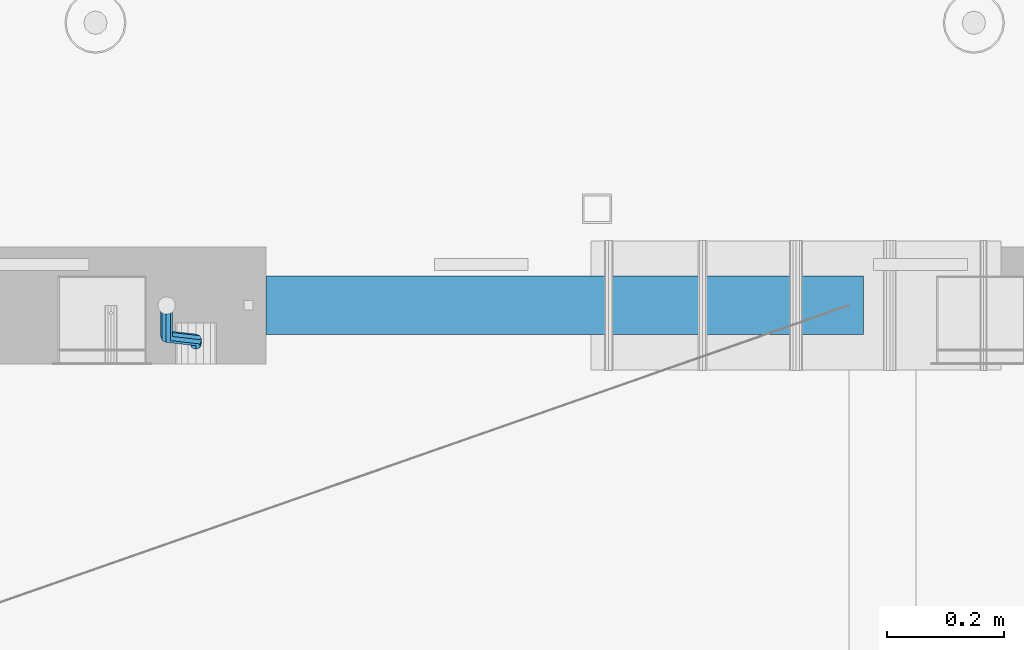
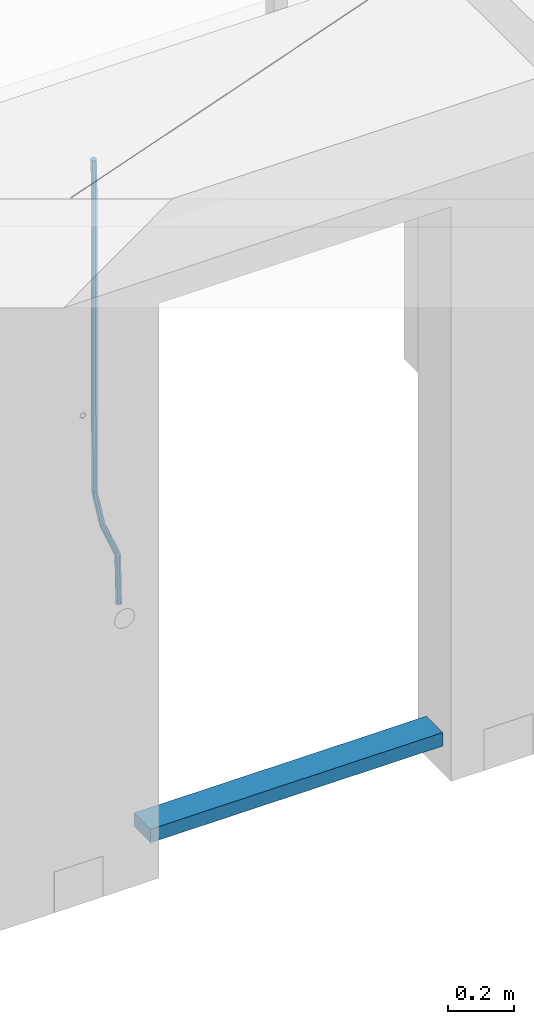
# One storey, part 95 of 309: 2 beams, 1 element without a shape of its own.
"""IFC2X3 building model written with IfcOpenShell, lengths in millimetres."""

from ifc_helpers import new_model, si_unit, frame, origin_with_axes, place, context, subcontext, project, spatial, faceted_brep, material, type_object, element, aggregate, save


model = new_model("IFC2X3")

# Units and contexts
model_context = context("Model", 3, precision=1e-05, world=origin_with_axes())
body_context = subcontext(model_context, "Body", "Model", "MODEL_VIEW")
ifc_project = project(units=[si_unit("LENGTHUNIT", "METRE", prefix="MILLI"), si_unit("AREAUNIT", "SQUARE_METRE"), si_unit("VOLUMEUNIT", "CUBIC_METRE"), si_unit("MASSUNIT", "GRAM", prefix="KILO"), si_unit("TIMEUNIT", "SECOND"), si_unit("PLANEANGLEUNIT", "RADIAN"), si_unit("SOLIDANGLEUNIT", "STERADIAN"), si_unit("THERMODYNAMICTEMPERATUREUNIT", "DEGREE_CELSIUS"), si_unit("LUMINOUSINTENSITYUNIT", "LUMEN")], contexts=[model_context])

# Site, building, storey
site_placement = place(None, origin_with_axes())
site = spatial("IfcSite", under=ifc_project, at=site_placement, CompositionType="ELEMENT")
building_placement = place(site_placement, origin_with_axes())
building = spatial("IfcBuilding", under=site, at=building_placement, CompositionType="ELEMENT")
storey_placement = place(building_placement, origin_with_axes())
storey = spatial("IfcBuildingStorey", under=building, at=storey_placement, Name="7", CompositionType="ELEMENT", Elevation=0.0)

# Assembly, beams
assembly_placement = place(storey_placement, origin_with_axes())
assembly = element("IfcElementAssembly", 1, at=assembly_placement, inside=storey, AssemblyPlace="NOTDEFINED", PredefinedType="REINFORCEMENT_UNIT")
ifc_material_1 = material()
beam_type_1 = type_object("IfcBeamType", Name="D20", PredefinedType="NOTDEFINED")
beam_1_placement = place(assembly_placement, frame((24379.9991455117, 15114.989587991, 100790.007632439), z_axis=(-0.000205762999925498, 0.999642804629538, -0.0267249099901004), x_axis=(4.30000201928125e-08, 0.0267249099948059, 0.999642825806181)))
beam_1 = element("IfcBeam", 2, at=beam_1_placement, type_object=beam_type_1, material=ifc_material_1, Name="JM20", ObjectType="D20", context=body_context, shape_type="Brep", body=[
    faceted_brep([(0.0, -10.0, 0.0), (-4.19531716033816e-08, -7.07106781186667, -7.07106781187031), (60.4266690400545, -7.0710677960451, -7.07106780570757), (60.4266690441291, -9.99999998418934, 6.15546014159918e-09), (0.0, 0.0, -10.0), (60.426669036824, 1.58106558956206e-08, -9.99999999384454), (4.196772351861e-08, 7.07106781186303, -7.07106781186667), (60.4266690363438, 7.07106782768096, -7.07106780570757), (0.0, 10.0, 0.0), (60.4266690388904, 10.0000000158179, 6.15182216279209e-09), (4.196772351861e-08, 7.07106781185939, 7.07106781185939), (60.4266690429649, 7.07106782768096, 7.07106781802577), (0.0, 0.0, 10.0), (60.4266690461809, 1.58179318532348e-08, 10.0000000061555), (-4.19531716033816e-08, -7.07106781187031, 7.07106781185939), (60.4266690466611, -7.07106779605238, 7.07106781802213), (61.0378400410118, -7.07106779588503, -7.07106780564936), (60.991799419251, -9.99999998403655, 6.21366780251265e-09), (61.0569027789461, 1.5985278878361e-08, -9.99999999378269), (61.0378209396877, 7.07106782784831, -7.07106780564936), (60.9917724058905, 10.0000000159635, 6.21366780251265e-09), (60.9457317841297, 7.07106782781193, 7.0710678180767), (60.9266690461809, 1.59488990902901e-08, 10.0000000062028), (60.9457508854539, -7.07106779591413, 7.0710678180767), (61.6489592143771, -7.07106614513759, -7.06310863441468), (61.5568818710308, -9.9999984576425, 0.00735959856683621), (61.6870830769039, 1.71821739058942e-06, -9.99179257185824), (61.6489210170112, 7.07106947854481, -7.06310888312146), (61.556827851804, 10.0000015422847, 0.00735924683976918), (61.4647505084577, 7.07106922979438, 7.07782747982128), (61.4266266459163, 1.36643211590126e-06, 10.0065114172685), (61.464788705809, -7.07106639389531, 7.07782772852806), (174.621213165461, -7.07076098345351, -5.59176629582907), (174.529135822144, -9.99969329595478, 1.4787019371488), (174.659337027944, 0.000306879905110691, -8.52045023327446), (174.621174967935, 7.07137464022526, -5.59176654453404), (174.529081802684, 10.0003067039688, 1.47870158543083), (174.437004459352, 7.07137439147118, 8.5491698184087), (174.398880596913, 0.000306528108922066, 11.4778537558541), (174.437042656878, -7.07076123221123, 8.54917006711185), (175.716094779258, -7.07075802595864, -5.57750663810293), (175.029093421879, -9.99969194546793, 1.48521334821271), (177.145578432857, 0.000313595744955819, -8.48806960781258), (178.480172245545, 7.07138506415868, -5.54150724740612), (178.938089262141, 10.0003186135946, 1.53612417477052), (178.251087904748, 7.07138469408164, 8.59884416108434), (176.821604251149, 0.000313072378048673, 11.5094071307958), (175.487010438475, -7.07075839603567, 8.56284477038935), (176.73028205616, -7.48306481911277, -5.5575978012148), (175.49220343327, -10.1879642774365, 1.49430435328395), (179.448580299344, -0.935946733912715, -8.44286090764945), (182.054755918522, 5.61817699831226, -5.47133696928722), (183.022146581905, 8.33998958468874, 1.61629559169705), (181.784067959001, 5.63509012636496, 8.6681977461958), (179.065769715831, -0.912027958831459, 11.5534608526305), (176.459594096654, -7.4661516910528, 8.58193691426459), (294.295456565174, -55.2779062578775, -3.24975393820569), (293.057377942285, -57.9828057162013, 3.80214821629306), (297.013754808359, -48.7307881726811, -6.13501704463852), (299.619930427536, -42.1766644404597, -3.16349310627629), (300.587321090919, -39.454851854076, 3.92413945470616), (299.34924246803, -42.1597513124034, 10.9760416092031), (296.630944224846, -48.7068693975998, 13.8613047156396), (294.024768605668, -55.2609931298248, 10.8897807772755), (300.131186042752, -57.6503585272258, -3.13519660847487), (297.927214299008, -59.9625846556301, 3.89774473963917), (302.241773597852, -50.8561822796182, -6.0323892798333), (303.022623399127, -43.5599922135116, -3.09669710035814), (302.016324223136, -40.0357975159677, 3.95219126616212), (299.812352479406, -42.3480236443684, 10.9851326142743), (297.701764924292, -49.1421998919686, 13.8823252856328), (296.920915123032, -56.4383899580826, 10.9466331061594), (305.816309115588, -57.6497962814865, -0.41917616768842), (302.671371672826, -59.9621154692577, 6.16422661461002), (307.334869561208, -50.8556785840192, -3.59920488503303), (306.337500895927, -43.5596643796707, -1.51304184353285), (303.408448157163, -40.0356598380822, 4.61726694041863), (300.263510714387, -42.3479790258461, 11.2006697227207), (298.744950268767, -49.1420967233171, 14.3806984400617), (299.742318934063, -56.4381109276655, 12.2945353985633), (395.630203780689, -57.6409138916788, 42.488667805259), (392.485266337913, -59.9532330794427, 49.0720705875574), (397.148764226309, -50.8467961942151, 39.3086390879143), (396.151395561013, -43.5507819898594, 41.3948021294145), (393.22234282225, -40.0267774482672, 47.5251109133696), (390.077405379474, -42.3390966360348, 54.1085136956717), (388.558844933854, -49.1332143335057, 57.2885424130127), (389.556213599149, -56.4292285378579, 55.2023793715125), (396.844209099741, -57.640793829316, 43.0686487871244), (395.280625423067, -59.9529566247911, 50.4075302279853), (397.599922461304, -50.8467515756856, 39.5241761963625), (397.10507886979, -43.5506876727486, 41.8504164279075), (395.649550989881, -40.0265374029004, 48.6846895034632), (394.085967313207, -42.3387001983865, 56.0235709443259), (393.330253951674, -49.1327424520096, 59.5680435350878), (393.825097543173, -56.4288063549466, 57.241803303541), (398.189189358192, -57.6411602552034, 43.0337942646147), (398.377566371972, -59.9538003541529, 50.3272744790011), (398.099754636642, -50.8468877497689, 39.5112232837091), (398.161651854258, -43.550975525075, 41.8230358424771), (398.338622460418, -40.027270012466, 48.6150034976581), (398.526999474212, -42.3399101114192, 55.9084837120445), (398.616434195777, -49.13418261685, 59.4310546929501), (398.554536978161, -56.4300948415512, 57.1192421341821), (1517.19478070838, -57.9460216934422, 14.0352975759452), (1517.38315772217, -60.2586617923953, 21.3287777903333), (1517.10534598683, -51.1517491880113, 10.5127265950414), (1517.16724320444, -43.8558369633138, 12.8245391538094), (1517.34421381062, -40.3321314507048, 19.6165068089904), (1517.53259082441, -42.6447715496579, 26.9099870233767), (1517.62202554596, -49.4390440550887, 30.4325580042841), (1517.56012832835, -56.7349562797899, 28.1207454455143), (1518.02724982343, -57.946248491, 14.0137245355054), (1518.07759034891, -60.258850983344, 21.3107818997123), (1517.99524544395, -51.1519916318648, 10.4896652746502), (1518.00032494192, -43.8560639277712, 12.8029502375484), (1518.03951281632, -40.3323208776928, 19.5984884665704), (1518.08985334181, -42.6449233700369, 26.8955458307773), (1518.12185772131, -49.4391802291757, 30.4196050916289), (1518.11677822332, -56.735107933262, 28.1063201287325), (1518.85992470267, -57.9437654472204, 14.0245252313944), (1518.77219462092, -60.2567796673247, 21.3197916701429), (1518.8853648605, -51.149337287974, 10.5012110884654), (1518.83361259502, -43.8535790567003, 12.8137588817826), (1518.73498368141, -40.3302469774862, 19.6075094776534), (1518.64725359967, -42.6432611975906, 26.9027759164019), (1518.62181344185, -49.4376893568369, 30.4260900593326), (1518.67356570732, -56.7334475881107, 28.1135422660154), (1618.76572350181, -57.6458454809253, 15.3204117501973), (1618.67799342007, -59.9588597010261, 22.6156781889458), (1618.79116365965, -50.8514173216718, 11.7970976072666), (1618.73941139416, -43.5556590904016, 14.1096454005838), (1618.64078248056, -40.032327011184, 20.9033959964545), (1618.55305239883, -42.3453412312883, 28.198662435203), (1618.52761224099, -49.1397693905419, 31.7219765781338), (1618.57936450648, -56.4355276218121, 29.4094287848166)], [[[0, 1, 2, 3]], [[1, 4, 5, 2]], [[4, 6, 7, 5]], [[6, 8, 9, 7]], [[8, 10, 11, 9]], [[10, 12, 13, 11]], [[12, 14, 15, 13]], [[14, 0, 3, 15]], [[14, 12, 10, 8, 6, 4, 1, 0]], [[3, 2, 16, 17]], [[2, 5, 18, 16]], [[5, 7, 19, 18]], [[7, 9, 20, 19]], [[9, 11, 21, 20]], [[11, 13, 22, 21]], [[13, 15, 23, 22]], [[15, 3, 17, 23]], [[17, 16, 24, 25]], [[16, 18, 26, 24]], [[18, 19, 27, 26]], [[19, 20, 28, 27]], [[20, 21, 29, 28]], [[21, 22, 30, 29]], [[22, 23, 31, 30]], [[23, 17, 25, 31]], [[25, 24, 32, 33]], [[24, 26, 34, 32]], [[26, 27, 35, 34]], [[27, 28, 36, 35]], [[28, 29, 37, 36]], [[29, 30, 38, 37]], [[30, 31, 39, 38]], [[31, 25, 33, 39]], [[33, 32, 40, 41]], [[32, 34, 42, 40]], [[34, 35, 43, 42]], [[35, 36, 44, 43]], [[36, 37, 45, 44]], [[37, 38, 46, 45]], [[38, 39, 47, 46]], [[39, 33, 41, 47]], [[41, 40, 48, 49]], [[40, 42, 50, 48]], [[42, 43, 51, 50]], [[43, 44, 52, 51]], [[44, 45, 53, 52]], [[45, 46, 54, 53]], [[46, 47, 55, 54]], [[47, 41, 49, 55]], [[49, 48, 56, 57]], [[48, 50, 58, 56]], [[50, 51, 59, 58]], [[51, 52, 60, 59]], [[52, 53, 61, 60]], [[53, 54, 62, 61]], [[54, 55, 63, 62]], [[55, 49, 57, 63]], [[57, 56, 64, 65]], [[56, 58, 66, 64]], [[58, 59, 67, 66]], [[59, 60, 68, 67]], [[60, 61, 69, 68]], [[61, 62, 70, 69]], [[62, 63, 71, 70]], [[63, 57, 65, 71]], [[65, 64, 72, 73]], [[64, 66, 74, 72]], [[66, 67, 75, 74]], [[67, 68, 76, 75]], [[68, 69, 77, 76]], [[69, 70, 78, 77]], [[70, 71, 79, 78]], [[71, 65, 73, 79]], [[73, 72, 80, 81]], [[72, 74, 82, 80]], [[74, 75, 83, 82]], [[75, 76, 84, 83]], [[76, 77, 85, 84]], [[77, 78, 86, 85]], [[78, 79, 87, 86]], [[79, 73, 81, 87]], [[81, 80, 88, 89]], [[80, 82, 90, 88]], [[82, 83, 91, 90]], [[83, 84, 92, 91]], [[84, 85, 93, 92]], [[85, 86, 94, 93]], [[86, 87, 95, 94]], [[87, 81, 89, 95]], [[89, 88, 96, 97]], [[88, 90, 98, 96]], [[90, 91, 99, 98]], [[91, 92, 100, 99]], [[92, 93, 101, 100]], [[93, 94, 102, 101]], [[94, 95, 103, 102]], [[95, 89, 97, 103]], [[97, 96, 104, 105]], [[96, 98, 106, 104]], [[98, 99, 107, 106]], [[99, 100, 108, 107]], [[100, 101, 109, 108]], [[101, 102, 110, 109]], [[102, 103, 111, 110]], [[103, 97, 105, 111]], [[105, 104, 112, 113]], [[104, 106, 114, 112]], [[106, 107, 115, 114]], [[107, 108, 116, 115]], [[108, 109, 117, 116]], [[109, 110, 118, 117]], [[110, 111, 119, 118]], [[111, 105, 113, 119]], [[113, 112, 120, 121]], [[112, 114, 122, 120]], [[114, 115, 123, 122]], [[115, 116, 124, 123]], [[116, 117, 125, 124]], [[117, 118, 126, 125]], [[118, 119, 127, 126]], [[119, 113, 121, 127]], [[121, 120, 128, 129]], [[120, 122, 130, 128]], [[122, 123, 131, 130]], [[123, 124, 132, 131]], [[124, 125, 133, 132]], [[125, 126, 134, 133]], [[126, 127, 135, 134]], [[127, 121, 129, 135]], [[130, 131, 132, 133, 134, 135, 129, 128]]]),
])
ifc_material_2 = material(Name="TIMBER/T24")
beam_type_2 = type_object("IfcBeamType", PredefinedType="NOTDEFINED")
beam_2_placement = place(assembly_placement, frame((24500.0006866455, 15180.0, 99880.0), z_axis=(0.0, 0.0, 1.0), x_axis=(1.0, 0.0, 0.0)))
beam_2 = element("IfcBeam", 3, at=beam_2_placement, type_object=beam_type_2, material=ifc_material_2, context=body_context, shape_type="Brep", body=[
    faceted_brep([(0.0, 50.0, -25.0), (0.0, 50.0, 25.0), (1020.0, 50.0, 25.0), (1020.0, 50.0, -25.0), (0.0, -50.0, 25.0), (1020.0, -50.0, 25.0), (0.0, -50.0, -25.0), (1020.0, -50.0, -25.0)], [[[0, 1, 2, 3]], [[1, 4, 5, 2]], [[4, 6, 7, 5]], [[6, 0, 3, 7]], [[5, 7, 3, 2]], [[6, 4, 1, 0]]]),
])
aggregate(assembly, [beam_1, beam_2])

save(model, "model.ifc")
